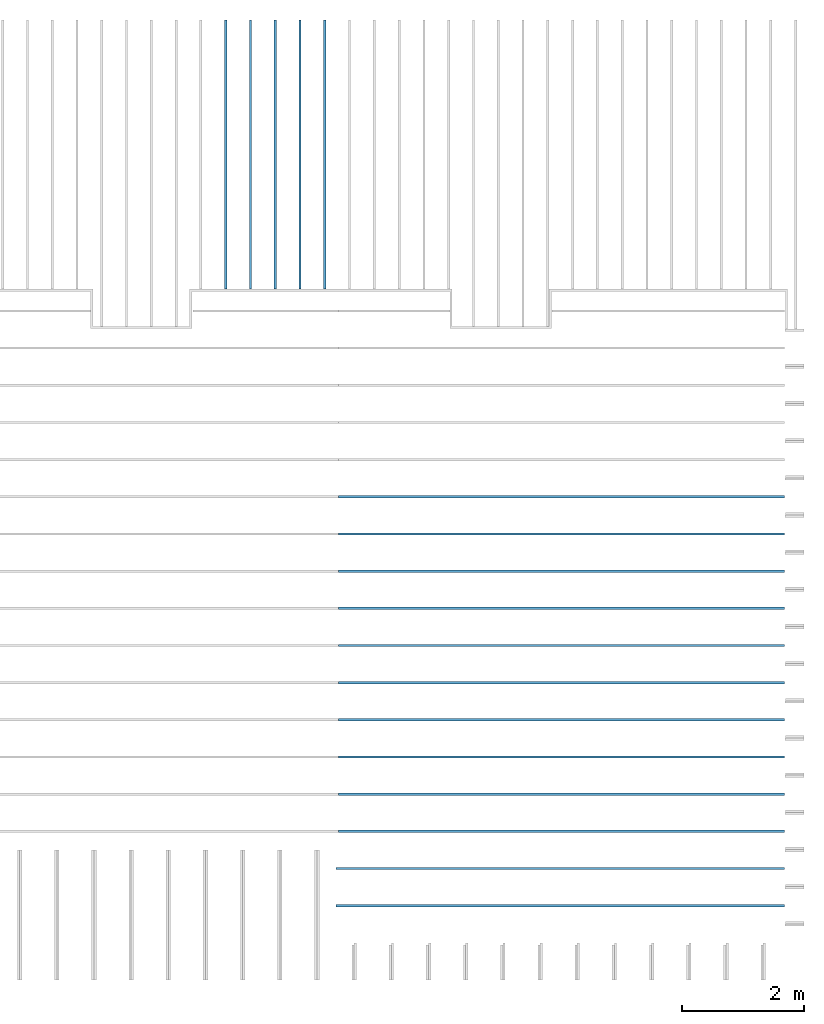
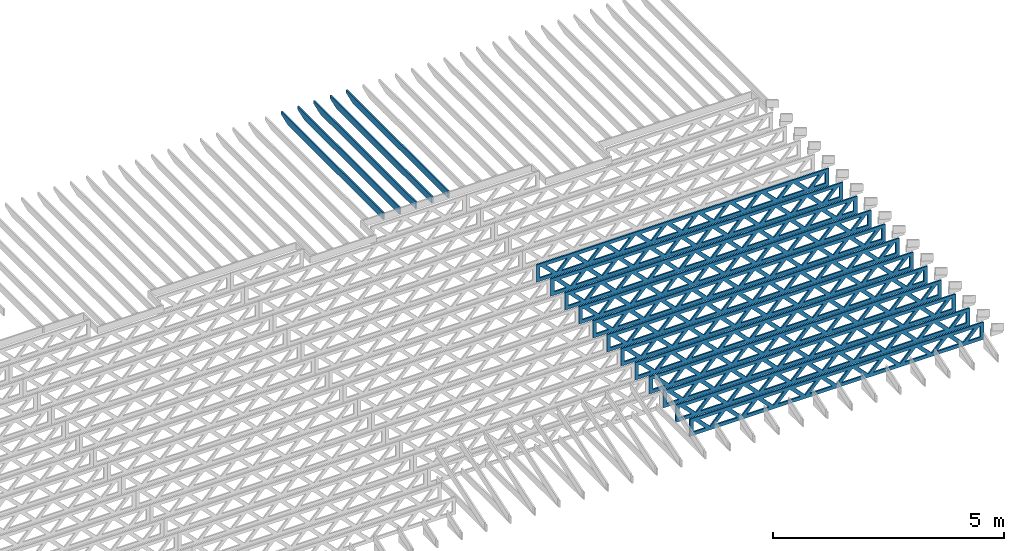
# One storey, part 11 of 17: 17 beams, 2 elements without a shape of their own.
"""IFC4 building model written with IfcOpenShell, lengths in feet."""

from ifc_helpers import new_model, entity, si_unit, converted_unit, derived_unit, direction, frame, frame_2d, origin, origin_2d_with_axis, place, context, subcontext, project, spatial, rectangle, extrude, clip, halfspace, source, transform, mapped, material, material_profile, profile_set, profile_usage, type_object, type_shapes, element, aggregate, save


model = new_model("IFC4")

# Units and contexts
model_context = context("Model", 3, precision=0.0001, world=origin(), true_north=direction((6.12303176911189e-17, 1.0)))
body_context = subcontext(model_context, "Body", "Model", "MODEL_VIEW")
ifc_project = project(units=[converted_unit("LENGTHUNIT", "FOOT", entity("IfcRatioMeasure", 0.3048), si_unit("LENGTHUNIT", "METRE"), dimensions=[1, 0, 0, 0, 0, 0, 0]), converted_unit("AREAUNIT", "SQUARE FOOT", entity("IfcRatioMeasure", 0.09290304), si_unit("AREAUNIT", "SQUARE_METRE"), dimensions=[2, 0, 0, 0, 0, 0, 0]), converted_unit("VOLUMEUNIT", "CUBIC FOOT", entity("IfcRatioMeasure", 0.028316846592), si_unit("VOLUMEUNIT", "CUBIC_METRE"), dimensions=[3, 0, 0, 0, 0, 0, 0]), converted_unit("PLANEANGLEUNIT", "DEGREE", entity("IfcRatioMeasure", 0.0174532925199433), si_unit("PLANEANGLEUNIT", "RADIAN"), dimensions=[0, 0, 0, 0, 0, 0, 0]), si_unit("MASSUNIT", "GRAM", prefix="KILO"), derived_unit("MASSDENSITYUNIT", [(si_unit("MASSUNIT", "GRAM", prefix="KILO"), 1), (si_unit("LENGTHUNIT", "METRE"), -3)]), derived_unit("MOMENTOFINERTIAUNIT", [(si_unit("LENGTHUNIT", "METRE"), 4)]), si_unit("TIMEUNIT", "SECOND"), si_unit("FREQUENCYUNIT", "HERTZ"), si_unit("THERMODYNAMICTEMPERATUREUNIT", "DEGREE_CELSIUS"), derived_unit("THERMALTRANSMITTANCEUNIT", [(si_unit("MASSUNIT", "GRAM", prefix="KILO"), 1), (si_unit("THERMODYNAMICTEMPERATUREUNIT", "KELVIN"), -1), (si_unit("TIMEUNIT", "SECOND"), -3)]), derived_unit("VOLUMETRICFLOWRATEUNIT", [(si_unit("LENGTHUNIT", "METRE"), 3), (si_unit("TIMEUNIT", "SECOND"), -1)]), si_unit("ELECTRICCURRENTUNIT", "AMPERE"), si_unit("ELECTRICVOLTAGEUNIT", "VOLT"), si_unit("POWERUNIT", "WATT"), si_unit("FORCEUNIT", "NEWTON"), si_unit("ILLUMINANCEUNIT", "LUX"), si_unit("LUMINOUSFLUXUNIT", "LUMEN"), si_unit("LUMINOUSINTENSITYUNIT", "CANDELA"), derived_unit("USERDEFINED", [(si_unit("MASSUNIT", "GRAM", prefix="KILO"), -1), (si_unit("LENGTHUNIT", "METRE"), -2), (si_unit("TIMEUNIT", "SECOND"), 3), (si_unit("LUMINOUSFLUXUNIT", "LUMEN"), 1)]), derived_unit("LINEARVELOCITYUNIT", [(si_unit("LENGTHUNIT", "METRE"), 1), (si_unit("TIMEUNIT", "SECOND"), -1)]), si_unit("PRESSUREUNIT", "PASCAL"), derived_unit("USERDEFINED", [(si_unit("LENGTHUNIT", "METRE"), -2), (si_unit("MASSUNIT", "GRAM", prefix="KILO"), 1), (si_unit("TIMEUNIT", "SECOND"), -2)]), derived_unit("LINEARFORCEUNIT", [(si_unit("MASSUNIT", "GRAM", prefix="KILO"), 1), (si_unit("LENGTHUNIT", "METRE"), 1), (si_unit("TIMEUNIT", "SECOND"), -2), (si_unit("LENGTHUNIT", "METRE"), -1)]), derived_unit("PLANARFORCEUNIT", [(si_unit("MASSUNIT", "GRAM", prefix="KILO"), 1), (si_unit("LENGTHUNIT", "METRE"), 1), (si_unit("TIMEUNIT", "SECOND"), -2), (si_unit("LENGTHUNIT", "METRE"), -2)])], contexts=[model_context])

# Site, building, storey
site_placement = place(None, origin())
site = spatial("IfcSite", under=ifc_project, at=site_placement, CompositionType="ELEMENT")
building_placement = place(site_placement, origin())
building = spatial("IfcBuilding", under=site, at=building_placement, CompositionType="ELEMENT")
storey_placement = place(building_placement, frame((0.0, 0.0, 30.4375000000082)))
storey = spatial("IfcBuildingStorey", under=building, at=storey_placement, Name="ROOF", CompositionType="ELEMENT", Elevation=30.4375000000082)

# Assembly, beams
assembly_1_placement = place(storey_placement, origin())
assembly_1 = element("IfcElementAssembly", 1, at=assembly_1_placement, inside=storey, Name="Structural Beam System:Structural Framing System", ObjectType="Structural Beam System:Structural Framing System", AssemblyPlace="NOTDEFINED", PredefinedType="BEAM_GRID")
ifc_material_1 = material(Name="WOOD TRUSS", Category="Materials")
ifc_material_profile_1 = material_profile(ifc_material_1, rectangle(XDim=1.73473973950632, YDim=0.125, at=origin_2d_with_axis()))
ifc_material_profile_2 = material_profile(ifc_material_1, rectangle(XDim=1.73473973950633, YDim=0.125, at=frame_2d((-1.11022302462516e-16, 0.0), x_axis=(1.0, 0.0))))
ifc_material_profile_3 = material_profile(ifc_material_1, rectangle(XDim=1.73473973950632, YDim=0.125, at=origin_2d_with_axis()))
ifc_material_profile_4 = material_profile(ifc_material_1, rectangle(XDim=1.73473973950633, YDim=0.125, at=origin_2d_with_axis()))
ifc_material_profile_5 = material_profile(ifc_material_1, rectangle(XDim=1.73473973950632, YDim=0.125, at=frame_2d((-5.55111512312578e-17, 0.0), x_axis=(1.0, 0.0))))
ifc_material_profile_6 = material_profile(ifc_material_1, rectangle(XDim=1.73473973950633, YDim=0.125, at=frame_2d((-2.77555756156289e-16, 0.0), x_axis=(1.0, 0.0))))
ifc_material_profile_7 = material_profile(ifc_material_1, rectangle(XDim=1.73473973950632, YDim=0.125, at=frame_2d((-4.9960036108132e-16, 0.0), x_axis=(1.0, 0.0))))
ifc_material_profile_8 = material_profile(ifc_material_1, rectangle(XDim=1.73473973950633, YDim=0.125, at=frame_2d((4.44089209850063e-16, 0.0), x_axis=(1.0, 0.0))))
ifc_material_profile_9 = material_profile(ifc_material_1, rectangle(XDim=1.73473973950632, YDim=0.125, at=origin_2d_with_axis()))
ifc_material_profile_10 = material_profile(ifc_material_1, rectangle(XDim=1.73473973950633, YDim=0.125, at=frame_2d((-4.9960036108132e-16, 0.0), x_axis=(1.0, 0.0))))
ifc_material_profile_11 = material_profile(ifc_material_1, rectangle(XDim=0.291666666666664, YDim=0.125, at=frame_2d((-2.77555756156289e-17, 0.0), x_axis=(1.0, 0.0))))
ifc_material_profile_12 = material_profile(ifc_material_1, rectangle(XDim=0.291666666666628, YDim=0.124999999999995, at=frame_2d((-5.55111512312578e-17, 0.0), x_axis=(1.0, 0.0))))
ifc_material_profile_13 = material_profile(ifc_material_1, rectangle(XDim=0.916666666666666, YDim=0.125000000000003, at=frame_2d((-2.77555756156289e-17, 0.0), x_axis=(1.0, 0.0))))
ifc_material_profile_14 = material_profile(ifc_material_1, rectangle(XDim=0.916666666666651, YDim=0.125, at=frame_2d((-2.77555756156289e-17, 0.0), x_axis=(1.0, 0.0))))
ifc_profile_set_1 = profile_set([ifc_material_profile_1, ifc_material_profile_2, ifc_material_profile_3, ifc_material_profile_4, ifc_material_profile_5, ifc_material_profile_6, ifc_material_profile_7, ifc_material_profile_8, ifc_material_profile_9, ifc_material_profile_10, ifc_material_profile_11, ifc_material_profile_12, ifc_material_profile_13, ifc_material_profile_14])
ifc_profile_usage_1 = profile_usage(ifc_profile_set_1, cardinal=8)
beam_type_1 = type_object("IfcBeamType", PredefinedType="BEAM", material=ifc_profile_set_1)
shared_shape_1 = source(origin(), body_context, "Body", "SweptSolid", [
    extrude(rectangle(XDim=1.73473973950632, YDim=0.125, at=frame_2d((8.88178419700125e-16, 0.0), x_axis=(1.0, 0.0))), frame((8.27006284966195, 0.0, 0.101118361020562), z_axis=(0.720569184836762, 0.0, -0.693383046997606), x_axis=(0.693383046997606, 0.0, 0.720569184836762)), (0.0, 0.0, 1.0), 0.291666666666667),
    extrude(rectangle(XDim=1.73473973950633, YDim=0.125, at=frame_2d((4.9960036108132e-16, 0.0), x_axis=(1.0, 0.0))), frame((7.01977697598868, 0.0, -0.101118361020407), z_axis=(0.720569184836758, 0.0, 0.69338304699761), x_axis=(0.69338304699761, 0.0, -0.720569184836758)), (0.0, 0.0, 1.0), 0.291666666666667),
    extrude(rectangle(XDim=1.73473973950632, YDim=0.125, at=origin_2d_with_axis()), frame((5.68672854334628, 0.0, 0.101118361020562), z_axis=(0.720569184836762, 0.0, -0.693383046997606), x_axis=(0.693383046997606, 0.0, 0.720569184836762)), (0.0, 0.0, 1.0), 0.291666666666667),
    extrude(rectangle(XDim=1.73473973950633, YDim=0.125, at=frame_2d((-4.9960036108132e-16, 0.0), x_axis=(1.0, 0.0))), frame((4.43644266967301, 0.0, -0.101118361020407), z_axis=(0.720569184836758, 0.0, 0.69338304699761), x_axis=(0.69338304699761, 0.0, -0.720569184836758)), (0.0, 0.0, 1.0), 0.291666666666667),
    extrude(rectangle(XDim=1.73473973950632, YDim=0.125, at=frame_2d((3.33066907387547e-16, 0.0), x_axis=(1.0, 0.0))), frame((3.10339423703061, 0.0, 0.101118361020562), z_axis=(0.720569184836762, 0.0, -0.693383046997606), x_axis=(0.693383046997606, 0.0, 0.720569184836762)), (0.0, 0.0, 1.0), 0.291666666666667),
    extrude(rectangle(XDim=1.73473973950633, YDim=0.125, at=frame_2d((-1.11022302462516e-16, 0.0), x_axis=(1.0, 0.0))), frame((1.85310836335734, 0.0, -0.101118361020407), z_axis=(0.720569184836758, 0.0, 0.69338304699761), x_axis=(0.69338304699761, 0.0, -0.720569184836758)), (0.0, 0.0, 1.0), 0.291666666666666),
    extrude(rectangle(XDim=1.73473973950632, YDim=0.125, at=frame_2d((5.55111512312578e-17, 0.0), x_axis=(1.0, 0.0))), frame((0.520059930714937, 0.0, 0.101118361020562), z_axis=(0.720569184836762, 0.0, -0.693383046997606), x_axis=(0.693383046997606, 0.0, 0.720569184836762)), (0.0, 0.0, 1.0), 0.291666666666667),
    extrude(rectangle(XDim=1.73473973950633, YDim=0.125, at=origin_2d_with_axis()), frame((-0.730225942958334, 0.0, -0.101118361020407), z_axis=(0.720569184836758, 0.0, 0.69338304699761), x_axis=(0.69338304699761, 0.0, -0.720569184836758)), (0.0, 0.0, 1.0), 0.291666666666666),
    extrude(rectangle(XDim=1.73473973950632, YDim=0.125, at=frame_2d((-5.55111512312578e-17, 0.0), x_axis=(1.0, 0.0))), frame((-2.06327437560074, 0.0, 0.101118361020562), z_axis=(0.720569184836762, 0.0, -0.693383046997606), x_axis=(0.693383046997606, 0.0, 0.720569184836762)), (0.0, 0.0, 1.0), 0.291666666666667),
    extrude(rectangle(XDim=1.73473973950633, YDim=0.125, at=frame_2d((-2.77555756156289e-16, 0.0), x_axis=(1.0, 0.0))), frame((-3.31356024927401, 0.0, -0.101118361020407), z_axis=(0.720569184836758, 0.0, 0.69338304699761), x_axis=(0.69338304699761, 0.0, -0.720569184836758)), (0.0, 0.0, 1.0), 0.291666666666666),
    extrude(rectangle(XDim=1.73473973950632, YDim=0.125, at=origin_2d_with_axis()), frame((-4.64660868191641, 0.0, 0.101118361020562), z_axis=(0.720569184836762, 0.0, -0.693383046997606), x_axis=(0.693383046997606, 0.0, 0.720569184836762)), (0.0, 0.0, 1.0), 0.291666666666667),
    extrude(rectangle(XDim=1.73473973950633, YDim=0.125, at=frame_2d((-4.9960036108132e-16, 0.0), x_axis=(1.0, 0.0))), frame((-5.89689455558968, 0.0, -0.101118361020407), z_axis=(0.720569184836758, 0.0, 0.69338304699761), x_axis=(0.69338304699761, 0.0, -0.720569184836758)), (0.0, 0.0, 1.0), 0.291666666666667),
    extrude(rectangle(XDim=1.73473973950632, YDim=0.125, at=frame_2d((5.55111512312578e-16, 0.0), x_axis=(1.0, 0.0))), frame((-7.22994298823208, 0.0, 0.101118361020562), z_axis=(0.720569184836762, 0.0, -0.693383046997606), x_axis=(0.693383046997606, 0.0, 0.720569184836762)), (0.0, 0.0, 1.0), 0.291666666666667),
    extrude(rectangle(XDim=1.73473973950633, YDim=0.125, at=origin_2d_with_axis()), frame((-8.48022886190535, 0.0, -0.101118361020407), z_axis=(0.720569184836758, 0.0, 0.69338304699761), x_axis=(0.69338304699761, 0.0, -0.720569184836758)), (0.0, 0.0, 1.0), 0.291666666666666),
    extrude(rectangle(XDim=1.73473973950632, YDim=0.125, at=frame_2d((-8.88178419700125e-16, 0.0), x_axis=(1.0, 0.0))), frame((10.8533971559776, 0.0, 0.101118361020503), z_axis=(0.720569184836762, 0.0, -0.693383046997606), x_axis=(0.693383046997606, 0.0, 0.720569184836762)), (0.0, 0.0, 1.0), 0.291666666666664),
    extrude(rectangle(XDim=1.73473973950633, YDim=0.125, at=origin_2d_with_axis()), frame((9.60311128230435, 0.0, -0.101118361020466), z_axis=(0.720569184836758, 0.0, 0.69338304699761), x_axis=(0.69338304699761, 0.0, -0.720569184836758)), (0.0, 0.0, 1.0), 0.291666666666666),
    extrude(rectangle(XDim=1.73473973950632, YDim=0.125, at=frame_2d((8.88178419700125e-16, 0.0), x_axis=(1.0, 0.0))), frame((-9.81327729454775, 0.0, 0.101118361020564), z_axis=(0.720569184836762, 0.0, -0.693383046997606), x_axis=(0.693383046997606, 0.0, 0.720569184836762)), (0.0, 0.0, 1.0), 0.291666666666667),
    extrude(rectangle(XDim=1.73473973950633, YDim=0.125, at=origin_2d_with_axis()), frame((-11.063563168221, 0.0, -0.101118361020405), z_axis=(0.720569184836758, 0.0, 0.69338304699761), x_axis=(0.69338304699761, 0.0, -0.720569184836758)), (0.0, 0.0, 1.0), 0.291666666666666),
    extrude(rectangle(XDim=0.291666666666664, YDim=0.125, at=frame_2d((-2.77555756156289e-17, 0.0), x_axis=(1.0, 0.0))), frame((-12.0000038919293, 0.0, 0.604166666666611), z_axis=(1.0, 0.0, 0.0), x_axis=(0.0, 0.0, -1.0)), (0.0, 0.0, 1.0), 24.0000077838585),
    extrude(rectangle(XDim=0.291666666666628, YDim=0.124999999999995, at=frame_2d((-5.55111512312578e-17, 0.0), x_axis=(1.0, 0.0))), frame((-12.0000038919291, 0.0, -0.604166666666693), z_axis=(1.0, 0.0, 0.0), x_axis=(0.0, 0.0, -1.0)), (0.0, 0.0, 1.0), 24.0000077838583),
    extrude(rectangle(XDim=0.916666666666666, YDim=0.125000000000003, at=frame_2d((-2.77555756156289e-17, 0.0), x_axis=(1.0, 0.0))), frame((11.7083372252626, 0.0, 0.0), z_axis=(1.0, 0.0, 0.0), x_axis=(0.0, 0.0, -1.0)), (0.0, 0.0, 1.0), 0.291666666666687),
    extrude(rectangle(XDim=0.916666666666651, YDim=0.125, at=frame_2d((-2.77555756156289e-17, 0.0), x_axis=(1.0, 0.0))), frame((-12.0000038919293, 0.0, 0.0), z_axis=(1.0, 0.0, 0.0), x_axis=(0.0, 0.0, -1.0)), (0.0, 0.0, 1.0), 0.291666666666687),
])
type_shapes(beam_type_1, [shared_shape_1])
beam_1_placement = place(assembly_1_placement, frame((-152.404823260266, 947.861934882651, 0.74999999999164), z_axis=(0.0, 0.0, 1.0), x_axis=(-1.0, 0.0, 0.0)))
beam_1 = element("IfcBeam", 2, at=beam_1_placement, type_object=beam_type_1, material=ifc_profile_usage_1, PredefinedType="BEAM", context=body_context, shape_type="MappedRepresentation", body=[
    mapped(shared_shape_1, transform((0.0, 0.0, 0.0), scale=1.0)),
])
ifc_profile_usage_2 = profile_usage(ifc_profile_set_1, cardinal=8)
beam_2_placement = place(assembly_1_placement, frame((-152.404823260266, 945.861934882651, 0.749999999991648), z_axis=(0.0, 0.0, 1.0), x_axis=(-1.0, 0.0, 0.0)))
beam_2 = element("IfcBeam", 3, at=beam_2_placement, type_object=beam_type_1, material=ifc_profile_usage_2, PredefinedType="BEAM", context=body_context, shape_type="MappedRepresentation", body=[
    mapped(shared_shape_1, transform((0.0, 0.0, 0.0), scale=1.0)),
])
ifc_profile_usage_3 = profile_usage(ifc_profile_set_1, cardinal=8)
beam_3_placement = place(assembly_1_placement, frame((-152.404823260266, 943.861934882651, 0.749999999991651), z_axis=(0.0, 0.0, 1.0), x_axis=(-1.0, 0.0, 0.0)))
beam_3 = element("IfcBeam", 4, at=beam_3_placement, type_object=beam_type_1, material=ifc_profile_usage_3, PredefinedType="BEAM", context=body_context, shape_type="MappedRepresentation", body=[
    mapped(shared_shape_1, transform((0.0, 0.0, 0.0), scale=1.0)),
])
ifc_profile_usage_4 = profile_usage(ifc_profile_set_1, cardinal=8)
beam_4_placement = place(assembly_1_placement, frame((-152.404823260266, 941.861934882651, 0.749999999991658), z_axis=(0.0, 0.0, 1.0), x_axis=(-1.0, 0.0, 0.0)))
beam_4 = element("IfcBeam", 5, at=beam_4_placement, type_object=beam_type_1, material=ifc_profile_usage_4, PredefinedType="BEAM", context=body_context, shape_type="MappedRepresentation", body=[
    mapped(shared_shape_1, transform((0.0, 0.0, 0.0), scale=1.0)),
])
ifc_profile_usage_5 = profile_usage(ifc_profile_set_1, cardinal=8)
beam_5_placement = place(assembly_1_placement, frame((-152.404823260266, 939.861934882651, 0.749999999991662), z_axis=(0.0, 0.0, 1.0), x_axis=(-1.0, 0.0, 0.0)))
beam_5 = element("IfcBeam", 6, at=beam_5_placement, type_object=beam_type_1, material=ifc_profile_usage_5, PredefinedType="BEAM", context=body_context, shape_type="MappedRepresentation", body=[
    mapped(shared_shape_1, transform((0.0, 0.0, 0.0), scale=1.0)),
])
ifc_profile_usage_6 = profile_usage(ifc_profile_set_1, cardinal=8)
beam_6_placement = place(assembly_1_placement, frame((-152.404823260266, 937.861934882651, 0.749999999991669), z_axis=(0.0, 0.0, 1.0), x_axis=(-1.0, 0.0, 0.0)))
beam_6 = element("IfcBeam", 7, at=beam_6_placement, type_object=beam_type_1, material=ifc_profile_usage_6, PredefinedType="BEAM", context=body_context, shape_type="MappedRepresentation", body=[
    mapped(shared_shape_1, transform((0.0, 0.0, 0.0), scale=1.0)),
])
ifc_profile_usage_7 = profile_usage(ifc_profile_set_1, cardinal=8)
beam_7_placement = place(assembly_1_placement, frame((-152.404823260266, 935.861934882651, 0.749999999991672), z_axis=(0.0, 0.0, 1.0), x_axis=(-1.0, 0.0, 0.0)))
beam_7 = element("IfcBeam", 8, at=beam_7_placement, type_object=beam_type_1, material=ifc_profile_usage_7, PredefinedType="BEAM", context=body_context, shape_type="MappedRepresentation", body=[
    mapped(shared_shape_1, transform((0.0, 0.0, 0.0), scale=1.0)),
])
ifc_profile_usage_8 = profile_usage(ifc_profile_set_1, cardinal=8)
beam_8_placement = place(assembly_1_placement, frame((-152.404823260266, 933.861934882651, 0.74999999999168), z_axis=(0.0, 0.0, 1.0), x_axis=(-1.0, 0.0, 0.0)))
beam_8 = element("IfcBeam", 9, at=beam_8_placement, type_object=beam_type_1, material=ifc_profile_usage_8, PredefinedType="BEAM", context=body_context, shape_type="MappedRepresentation", body=[
    mapped(shared_shape_1, transform((0.0, 0.0, 0.0), scale=1.0)),
])
ifc_profile_usage_9 = profile_usage(ifc_profile_set_1, cardinal=8)
beam_9_placement = place(assembly_1_placement, frame((-152.404823260266, 931.861934882651, 0.749999999991687), z_axis=(0.0, 0.0, 1.0), x_axis=(-1.0, 0.0, 0.0)))
beam_9 = element("IfcBeam", 10, at=beam_9_placement, type_object=beam_type_1, material=ifc_profile_usage_9, PredefinedType="BEAM", context=body_context, shape_type="MappedRepresentation", body=[
    mapped(shared_shape_1, transform((0.0, 0.0, 0.0), scale=1.0)),
])
ifc_profile_usage_10 = profile_usage(ifc_profile_set_1, cardinal=8)
beam_10_placement = place(assembly_1_placement, frame((-152.404823260266, 929.861934882651, 0.74999999999169), z_axis=(0.0, 0.0, 1.0), x_axis=(-1.0, 0.0, 0.0)))
beam_10 = element("IfcBeam", 11, at=beam_10_placement, type_object=beam_type_1, material=ifc_profile_usage_10, PredefinedType="BEAM", context=body_context, shape_type="MappedRepresentation", body=[
    mapped(shared_shape_1, transform((0.0, 0.0, 0.0), scale=1.0)),
])
ifc_profile_usage_11 = profile_usage(ifc_profile_set_1, cardinal=8)
beam_type_2 = type_object("IfcBeamType", PredefinedType="BEAM", material=ifc_profile_set_1)
shared_shape_2 = source(origin(), body_context, "Body", "SweptSolid", [
    extrude(rectangle(XDim=1.73473973950632, YDim=0.125, at=frame_2d((8.88178419700125e-16, 0.0), x_axis=(1.0, 0.0))), frame((8.31693784968716, 0.0, 0.101118361020562), z_axis=(0.720569184836762, 0.0, -0.693383046997606), x_axis=(0.693383046997606, 0.0, 0.720569184836762)), (0.0, 0.0, 1.0), 0.291666666666667),
    extrude(rectangle(XDim=1.73473973950633, YDim=0.125, at=frame_2d((4.9960036108132e-16, 0.0), x_axis=(1.0, 0.0))), frame((7.06665197601389, 0.0, -0.101118361020407), z_axis=(0.720569184836758, 0.0, 0.69338304699761), x_axis=(0.69338304699761, 0.0, -0.720569184836758)), (0.0, 0.0, 1.0), 0.291666666666667),
    extrude(rectangle(XDim=1.73473973950632, YDim=0.125, at=origin_2d_with_axis()), frame((5.71797854336309, 0.0, 0.101118361020562), z_axis=(0.720569184836762, 0.0, -0.693383046997606), x_axis=(0.693383046997606, 0.0, 0.720569184836762)), (0.0, 0.0, 1.0), 0.291666666666667),
    extrude(rectangle(XDim=1.73473973950633, YDim=0.125, at=frame_2d((-4.9960036108132e-16, 0.0), x_axis=(1.0, 0.0))), frame((4.46769266968982, 0.0, -0.101118361020407), z_axis=(0.720569184836758, 0.0, 0.69338304699761), x_axis=(0.69338304699761, 0.0, -0.720569184836758)), (0.0, 0.0, 1.0), 0.291666666666667),
    extrude(rectangle(XDim=1.73473973950632, YDim=0.125, at=frame_2d((3.33066907387547e-16, 0.0), x_axis=(1.0, 0.0))), frame((3.11901923703901, 0.0, 0.101118361020562), z_axis=(0.720569184836762, 0.0, -0.693383046997606), x_axis=(0.693383046997606, 0.0, 0.720569184836762)), (0.0, 0.0, 1.0), 0.291666666666667),
    extrude(rectangle(XDim=1.73473973950633, YDim=0.125, at=frame_2d((-1.11022302462516e-16, 0.0), x_axis=(1.0, 0.0))), frame((1.86873336336574, 0.0, -0.101118361020407), z_axis=(0.720569184836758, 0.0, 0.69338304699761), x_axis=(0.69338304699761, 0.0, -0.720569184836758)), (0.0, 0.0, 1.0), 0.291666666666666),
    extrude(rectangle(XDim=1.73473973950632, YDim=0.125, at=frame_2d((5.55111512312578e-17, 0.0), x_axis=(1.0, 0.0))), frame((0.520059930714937, 0.0, 0.101118361020562), z_axis=(0.720569184836762, 0.0, -0.693383046997606), x_axis=(0.693383046997606, 0.0, 0.720569184836762)), (0.0, 0.0, 1.0), 0.291666666666667),
    extrude(rectangle(XDim=1.73473973950633, YDim=0.125, at=origin_2d_with_axis()), frame((-0.730225942958334, 0.0, -0.101118361020407), z_axis=(0.720569184836758, 0.0, 0.69338304699761), x_axis=(0.69338304699761, 0.0, -0.720569184836758)), (0.0, 0.0, 1.0), 0.291666666666666),
    extrude(rectangle(XDim=1.73473973950632, YDim=0.125, at=frame_2d((-5.55111512312578e-17, 0.0), x_axis=(1.0, 0.0))), frame((-2.07889937560914, 0.0, 0.101118361020562), z_axis=(0.720569184836762, 0.0, -0.693383046997606), x_axis=(0.693383046997606, 0.0, 0.720569184836762)), (0.0, 0.0, 1.0), 0.291666666666667),
    extrude(rectangle(XDim=1.73473973950633, YDim=0.125, at=frame_2d((-2.77555756156289e-16, 0.0), x_axis=(1.0, 0.0))), frame((-3.32918524928241, 0.0, -0.101118361020407), z_axis=(0.720569184836758, 0.0, 0.69338304699761), x_axis=(0.69338304699761, 0.0, -0.720569184836758)), (0.0, 0.0, 1.0), 0.291666666666666),
    extrude(rectangle(XDim=1.73473973950632, YDim=0.125, at=origin_2d_with_axis()), frame((-4.67785868193321, 0.0, 0.101118361020562), z_axis=(0.720569184836762, 0.0, -0.693383046997606), x_axis=(0.693383046997606, 0.0, 0.720569184836762)), (0.0, 0.0, 1.0), 0.291666666666667),
    extrude(rectangle(XDim=1.73473973950633, YDim=0.125, at=frame_2d((-4.9960036108132e-16, 0.0), x_axis=(1.0, 0.0))), frame((-5.92814455560648, 0.0, -0.101118361020407), z_axis=(0.720569184836758, 0.0, 0.69338304699761), x_axis=(0.69338304699761, 0.0, -0.720569184836758)), (0.0, 0.0, 1.0), 0.291666666666667),
    extrude(rectangle(XDim=1.73473973950632, YDim=0.125, at=frame_2d((-5.55111512312578e-16, 0.0), x_axis=(1.0, 0.0))), frame((-7.27681798825729, 0.0, 0.101118361020562), z_axis=(0.720569184836762, 0.0, -0.693383046997606), x_axis=(0.693383046997606, 0.0, 0.720569184836762)), (0.0, 0.0, 1.0), 0.291666666666667),
    extrude(rectangle(XDim=1.73473973950633, YDim=0.125, at=origin_2d_with_axis()), frame((-8.52710386193056, 0.0, -0.101118361020407), z_axis=(0.720569184836758, 0.0, 0.69338304699761), x_axis=(0.69338304699761, 0.0, -0.720569184836758)), (0.0, 0.0, 1.0), 0.291666666666666),
    extrude(rectangle(XDim=1.73473973950632, YDim=0.125, at=frame_2d((-1.0547118733939e-15, 0.0), x_axis=(1.0, 0.0))), frame((10.9158971560112, 0.0, 0.101118361020503), z_axis=(0.720569184836762, 0.0, -0.693383046997606), x_axis=(0.693383046997606, 0.0, 0.720569184836762)), (0.0, 0.0, 1.0), 0.291666666666664),
    extrude(rectangle(XDim=1.73473973950633, YDim=0.125, at=origin_2d_with_axis()), frame((9.66561128233796, 0.0, -0.101118361020466), z_axis=(0.720569184836758, 0.0, 0.69338304699761), x_axis=(0.69338304699761, 0.0, -0.720569184836758)), (0.0, 0.0, 1.0), 0.291666666666666),
    extrude(rectangle(XDim=1.73473973950632, YDim=0.125, at=frame_2d((9.43689570931383e-16, 0.0), x_axis=(1.0, 0.0))), frame((-9.87577729458136, 0.0, 0.101118361020564), z_axis=(0.720569184836762, 0.0, -0.693383046997606), x_axis=(0.693383046997606, 0.0, 0.720569184836762)), (0.0, 0.0, 1.0), 0.291666666666667),
    extrude(rectangle(XDim=1.73473973950633, YDim=0.125, at=origin_2d_with_axis()), frame((-11.1260631682546, 0.0, -0.101118361020405), z_axis=(0.720569184836758, 0.0, 0.69338304699761), x_axis=(0.69338304699761, 0.0, -0.720569184836758)), (0.0, 0.0, 1.0), 0.291666666666666),
    extrude(rectangle(XDim=0.291666666666664, YDim=0.125, at=frame_2d((-2.77555756156289e-17, 0.0), x_axis=(1.0, 0.0))), frame((-12.0625038919629, 0.0, 0.604166666666611), z_axis=(1.0, 0.0, 0.0), x_axis=(0.0, 0.0, -1.0)), (0.0, 0.0, 1.0), 24.1250077839258),
    extrude(rectangle(XDim=0.291666666666628, YDim=0.124999999999995, at=frame_2d((-5.55111512312578e-17, 0.0), x_axis=(1.0, 0.0))), frame((-12.0625038919627, 0.0, -0.604166666666693), z_axis=(1.0, 0.0, 0.0), x_axis=(0.0, 0.0, -1.0)), (0.0, 0.0, 1.0), 24.1250077839255),
    extrude(rectangle(XDim=0.916666666666666, YDim=0.125000000000003, at=frame_2d((-2.77555756156289e-17, 0.0), x_axis=(1.0, 0.0))), frame((11.7708372252962, 0.0, 0.0), z_axis=(1.0, 0.0, 0.0), x_axis=(0.0, 0.0, -1.0)), (0.0, 0.0, 1.0), 0.291666666666687),
    extrude(rectangle(XDim=0.916666666666651, YDim=0.125, at=frame_2d((-2.77555756156289e-17, -6.93889390390723e-18), x_axis=(1.0, 0.0))), frame((-12.0625038919629, 0.0, 0.0), z_axis=(1.0, 0.0, 0.0), x_axis=(0.0, 0.0, -1.0)), (0.0, 0.0, 1.0), 0.291666666666687),
])
type_shapes(beam_type_2, [shared_shape_2])
beam_11_placement = place(assembly_1_placement, frame((-152.4673232603, 927.861934882651, 0.749999999991697), z_axis=(0.0, 0.0, 1.0), x_axis=(-1.0, 0.0, 0.0)))
beam_11 = element("IfcBeam", 12, at=beam_11_placement, type_object=beam_type_2, material=ifc_profile_usage_11, PredefinedType="BEAM", context=body_context, shape_type="MappedRepresentation", body=[
    mapped(shared_shape_2, transform((0.0, 0.0, 0.0), scale=1.0)),
])
ifc_profile_usage_12 = profile_usage(ifc_profile_set_1, cardinal=8)
beam_12_placement = place(assembly_1_placement, frame((-152.4673232603, 925.861934882651, 0.749999999991701), z_axis=(0.0, 0.0, 1.0), x_axis=(-1.0, 0.0, 0.0)))
beam_12 = element("IfcBeam", 13, at=beam_12_placement, type_object=beam_type_2, material=ifc_profile_usage_12, PredefinedType="BEAM", context=body_context, shape_type="MappedRepresentation", body=[
    mapped(shared_shape_2, transform((0.0, 0.0, 0.0), scale=1.0)),
])
aggregate(assembly_1, [beam_1, beam_2, beam_3, beam_4, beam_5, beam_6, beam_7, beam_8, beam_9, beam_10, beam_11, beam_12])

assembly_2_placement = place(storey_placement, origin())
assembly_2 = element("IfcElementAssembly", 14, at=assembly_2_placement, inside=storey, Name="Structural Beam System:Structural Framing System", ObjectType="Structural Beam System:Structural Framing System", AssemblyPlace="NOTDEFINED", PredefinedType="BEAM_GRID")
ifc_material_2 = material(Name="2X ROOF JOISTS - EXT. STAIN-1 - SEE LIFE SAFETY", Category="Materials")
ifc_material_profile_15 = material_profile(ifc_material_2, rectangle(XDim=0.604166666666667, YDim=0.125000000000011, at=frame_2d((0.0, 0.0), x_axis=(0.0, 1.0))))
ifc_profile_set_2 = profile_set([ifc_material_profile_15])
ifc_profile_usage_13 = profile_usage(ifc_profile_set_2, cardinal=8)
beam_type_3 = type_object("IfcBeamType", PredefinedType="BEAM", material=ifc_profile_set_2)
shared_shape_3 = source(origin(), body_context, "Body", "Clipping", [
    clip(extrude(rectangle(XDim=0.604166666666667, YDim=0.125000000000011, at=frame_2d((0.0, 0.0), x_axis=(0.0, 1.0))), frame((-7.24296428465033, 0.0, 0.0), z_axis=(1.0, 0.0, 0.0), x_axis=(0.0, 1.0, 0.0)), (0.0, 0.0, 1.0), 14.4859285693007), halfspace(frame((-6.2698993652601, -0.0625000000000026, -0.30208333333334), z_axis=(-0.34202014332567, 0.0, -0.939692620785908), x_axis=(0.0, 1.0, 0.0)), False)),
])
type_shapes(beam_type_3, [shared_shape_3])
beam_13_placement = place(assembly_2_placement, frame((-165.133993818795, 966.271566744423, 1.07291666665829), z_axis=(0.0, 0.0, 1.0), x_axis=(0.0, -1.0, 0.0)))
beam_13 = element("IfcBeam", 15, at=beam_13_placement, type_object=beam_type_3, material=ifc_profile_usage_13, PredefinedType="BEAM", context=body_context, shape_type="MappedRepresentation", body=[
    mapped(shared_shape_3, transform((0.0, 0.0, 0.0), scale=1.0)),
])
ifc_profile_usage_14 = profile_usage(ifc_profile_set_2, cardinal=8)
beam_type_4 = type_object("IfcBeamType", PredefinedType="BEAM", material=ifc_profile_set_2)
shared_shape_4 = source(origin(), body_context, "Body", "Clipping", [
    clip(extrude(rectangle(XDim=0.604166666666667, YDim=0.125000000000011, at=frame_2d((0.0, 0.0), x_axis=(0.0, 1.0))), frame((-7.24296445215151, 0.0, 0.0), z_axis=(1.0, 0.0, 0.0), x_axis=(0.0, 1.0, 0.0)), (0.0, 0.0, 1.0), 14.485928904303), halfspace(frame((-6.26989953276129, -0.0625000000000026, -0.30208333333334), z_axis=(-0.34202014332567, 0.0, -0.939692620785908), x_axis=(0.0, 1.0, 0.0)), False)),
])
type_shapes(beam_type_4, [shared_shape_4])
beam_14_placement = place(assembly_2_placement, frame((-166.467327152128, 966.271566576922, 1.07291666665829), z_axis=(0.0, 0.0, 1.0), x_axis=(0.0, -1.0, 0.0)))
beam_14 = element("IfcBeam", 16, at=beam_14_placement, type_object=beam_type_4, material=ifc_profile_usage_14, PredefinedType="BEAM", context=body_context, shape_type="MappedRepresentation", body=[
    mapped(shared_shape_4, transform((0.0, 0.0, 0.0), scale=1.0)),
])
ifc_profile_usage_15 = profile_usage(ifc_profile_set_2, cardinal=8)
beam_type_5 = type_object("IfcBeamType", PredefinedType="BEAM", material=ifc_profile_set_2)
shared_shape_5 = source(origin(), body_context, "Body", "Clipping", [
    clip(extrude(rectangle(XDim=0.604166666666667, YDim=0.125000000000011, at=frame_2d((0.0, 0.0), x_axis=(0.0, 1.0))), frame((-7.2429646196527, 0.0, 0.0), z_axis=(1.0, 0.0, 0.0), x_axis=(0.0, 1.0, 0.0)), (0.0, 0.0, 1.0), 14.4859292393054), halfspace(frame((-6.26989970026247, -0.0625000000000026, -0.30208333333334), z_axis=(-0.34202014332567, 0.0, -0.939692620785908), x_axis=(0.0, 1.0, 0.0)), False)),
])
type_shapes(beam_type_5, [shared_shape_5])
beam_15_placement = place(assembly_2_placement, frame((-167.800660485462, 966.271566409421, 1.07291666665829), z_axis=(0.0, 0.0, 1.0), x_axis=(0.0, -1.0, 0.0)))
beam_15 = element("IfcBeam", 17, at=beam_15_placement, type_object=beam_type_5, material=ifc_profile_usage_15, PredefinedType="BEAM", context=body_context, shape_type="MappedRepresentation", body=[
    mapped(shared_shape_5, transform((0.0, 0.0, 0.0), scale=1.0)),
])
ifc_profile_usage_16 = profile_usage(ifc_profile_set_2, cardinal=8)
beam_type_6 = type_object("IfcBeamType", PredefinedType="BEAM", material=ifc_profile_set_2)
shared_shape_6 = source(origin(), body_context, "Body", "Clipping", [
    clip(extrude(rectangle(XDim=0.604166666666667, YDim=0.125000000000011, at=frame_2d((0.0, 0.0), x_axis=(0.0, 1.0))), frame((-7.24296478715382, 0.0, 0.0), z_axis=(1.0, 0.0, 0.0), x_axis=(0.0, 1.0, 0.0)), (0.0, 0.0, 1.0), 14.4859295743076), halfspace(frame((-6.2698998677636, -0.0625000000000026, -0.30208333333334), z_axis=(-0.34202014332567, 0.0, -0.939692620785908), x_axis=(0.0, 1.0, 0.0)), False)),
])
type_shapes(beam_type_6, [shared_shape_6])
beam_16_placement = place(assembly_2_placement, frame((-169.133993818795, 966.271566241919, 1.07291666665829), z_axis=(0.0, 0.0, 1.0), x_axis=(0.0, -1.0, 0.0)))
beam_16 = element("IfcBeam", 18, at=beam_16_placement, type_object=beam_type_6, material=ifc_profile_usage_16, PredefinedType="BEAM", context=body_context, shape_type="MappedRepresentation", body=[
    mapped(shared_shape_6, transform((0.0, 0.0, 0.0), scale=1.0)),
])
ifc_profile_usage_17 = profile_usage(ifc_profile_set_2, cardinal=8)
beam_type_7 = type_object("IfcBeamType", PredefinedType="BEAM", material=ifc_profile_set_2)
shared_shape_7 = source(origin(), body_context, "Body", "Clipping", [
    clip(extrude(rectangle(XDim=0.604166666666667, YDim=0.125000000000011, at=frame_2d((0.0, 0.0), x_axis=(0.0, 1.0))), frame((-7.24296495465501, 0.0, 0.0), z_axis=(1.0, 0.0, 0.0), x_axis=(0.0, 1.0, 0.0)), (0.0, 0.0, 1.0), 14.48592990931), halfspace(frame((-6.26990003526478, -0.0625000000000026, -0.30208333333334), z_axis=(-0.34202014332567, 0.0, -0.939692620785908), x_axis=(0.0, 1.0, 0.0)), False)),
])
type_shapes(beam_type_7, [shared_shape_7])
beam_17_placement = place(assembly_2_placement, frame((-170.467327152128, 966.271566074418, 1.07291666665829), z_axis=(0.0, 0.0, 1.0), x_axis=(0.0, -1.0, 0.0)))
beam_17 = element("IfcBeam", 19, at=beam_17_placement, type_object=beam_type_7, material=ifc_profile_usage_17, PredefinedType="BEAM", context=body_context, shape_type="MappedRepresentation", body=[
    mapped(shared_shape_7, transform((0.0, 0.0, 0.0), scale=1.0)),
])
aggregate(assembly_2, [beam_13, beam_14, beam_15, beam_16, beam_17])

save(model, "model.ifc")
